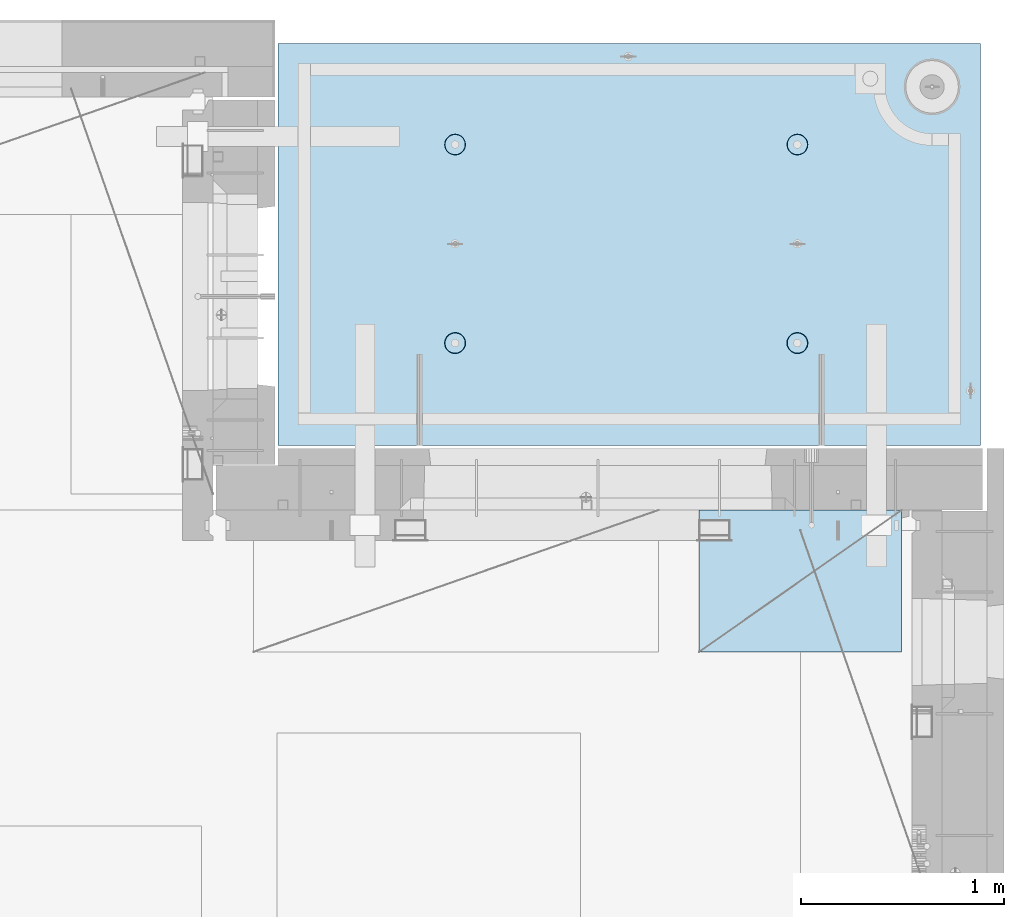
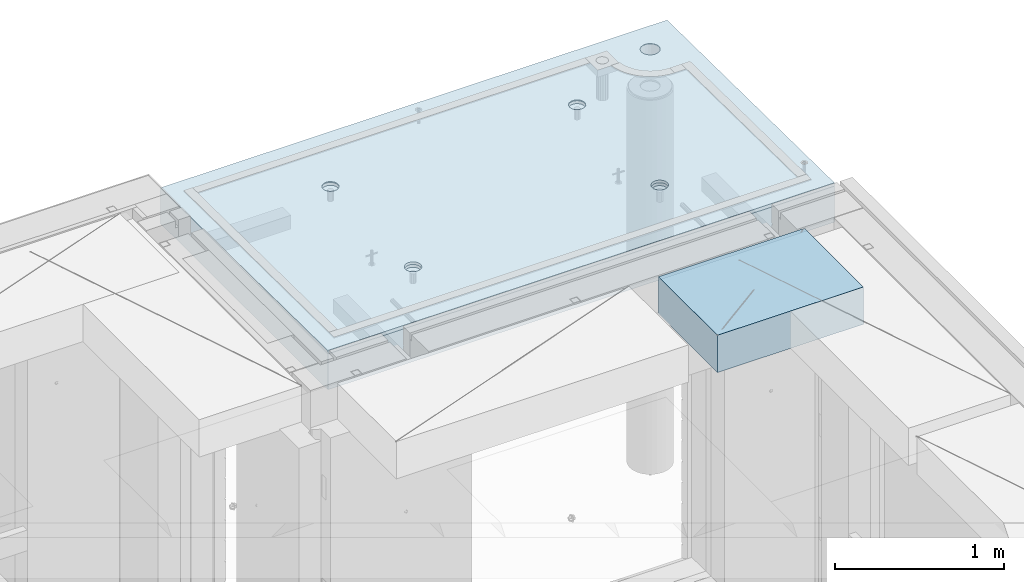
# One storey, part 211 of 349: 2 slabs, 1 plate, 2 elements without a shape of their own.
"""IFC2X3 building model written with IfcOpenShell, lengths in millimetres."""

from ifc_helpers import new_model, si_unit, frame, origin_with_axes, place, context, subcontext, project, spatial, faceted_brep, material, type_object, element, aggregate, save


model = new_model("IFC2X3")

# Units and contexts
model_context = context("Model", 3, precision=1e-05, world=origin_with_axes())
body_context = subcontext(model_context, "Body", "Model", "MODEL_VIEW")
ifc_project = project(units=[si_unit("LENGTHUNIT", "METRE", prefix="MILLI"), si_unit("AREAUNIT", "SQUARE_METRE"), si_unit("VOLUMEUNIT", "CUBIC_METRE"), si_unit("MASSUNIT", "GRAM", prefix="KILO"), si_unit("TIMEUNIT", "SECOND"), si_unit("PLANEANGLEUNIT", "RADIAN"), si_unit("SOLIDANGLEUNIT", "STERADIAN"), si_unit("THERMODYNAMICTEMPERATUREUNIT", "DEGREE_CELSIUS"), si_unit("LUMINOUSINTENSITYUNIT", "LUMEN")], contexts=[model_context])

# Site, building, storey
site_placement = place(None, origin_with_axes())
site = spatial("IfcSite", under=ifc_project, at=site_placement, CompositionType="ELEMENT")
building_placement = place(site_placement, origin_with_axes())
building = spatial("IfcBuilding", under=site, at=building_placement, CompositionType="ELEMENT")
storey_placement = place(building_placement, origin_with_axes())
storey = spatial("IfcBuildingStorey", under=building, at=storey_placement, Name="4", CompositionType="ELEMENT", Elevation=0.0)

# Assembly, slabs
assembly_1_placement = place(storey_placement, origin_with_axes())
assembly_1 = element("IfcElementAssembly", 1, at=assembly_1_placement, inside=storey, AssemblyPlace="NOTDEFINED", PredefinedType="REINFORCEMENT_UNIT")
ifc_material_1 = material(Name="CONCRETE/C35/45")
slab_type_1 = type_object("IfcSlabType", PredefinedType="NOTDEFINED")
slab_1_placement = place(assembly_1_placement, frame((31779.9998568133, 20899.9965573523, 93717.5), z_axis=(0.0, 1.0, 0.0), x_axis=(1.0, 0.0, 0.0)))
slab_1 = element("IfcSlab", 2, at=slab_1_placement, type_object=slab_type_1, material=ifc_material_1, PredefinedType="FLOOR", context=body_context, shape_type="Brep", body=[
    faceted_brep([(3287.06232936882, 9.55874156874779, 1751.46731182328), (3287.06232936882, 12.4999999999563, 1751.46731182328), (3278.5399580536, 12.4999999999563, 1734.74121634823), (3278.5399580536, 9.3480858430994, 1734.74121634823), (3265.26605352866, 12.4999999999563, 1721.46731182328), (3265.26605352866, 9.18090851265879, 1721.46731182328), (3248.5399580536, 12.4999999999563, 1712.94494050807), (3248.5399580536, 9.07357405936637, 1712.94494050807), (3229.99893839111, 12.4999999999563, 1710.00833148578), (3229.99893839111, 9.03658912732499, 1710.00833148578), (3211.45791872861, 12.4999999999563, 1712.94494050807), (3211.45791872861, 9.07357405936637, 1712.94494050807), (3194.73182325356, 12.4999999999563, 1721.46731182328), (3194.73182325356, 9.18090851267334, 1721.46731182328), (3181.45791872861, 12.4999999999563, 1734.74121634823), (3181.45791872861, 9.3480858430994, 1734.74121634823), (3172.9355474134, 12.4999999999563, 1751.46731182328), (3172.9355474134, 9.55874156874779, 1751.46731182328), (3169.99893839111, 12.4999999999563, 1770.00833148578), (3169.99893839111, 9.79225523948844, 1770.00833148578), (3172.9355474134, 12.4999999999563, 1788.54935114827), (3172.9355474134, 10.0257689102291, 1788.54935114827), (3181.45791872861, 12.4999999999563, 1805.27544662332), (3181.45791872861, 10.236424635892, 1805.27544662332), (3194.73182325356, 12.4999999999563, 1818.54935114827), (3194.73182325356, 10.4036019663181, 1818.54935114827), (3211.45791872861, 12.4999999999563, 1827.07172246349), (3211.45791872861, 10.5109364196105, 1827.07172246349), (3229.99893839111, 12.4999999999563, 1830.00833148578), (3229.99893839111, 10.5479213516664, 1830.00833148578), (3248.5399580536, 12.4999999999563, 1827.07172246349), (3248.5399580536, 10.5109364196105, 1827.07172246349), (3265.26605352866, 12.4999999999563, 1818.54935114827), (3265.26605352866, 10.4036019663181, 1818.54935114827), (3278.5399580536, 12.4999999999563, 1805.27544662332), (3278.5399580536, 10.2364246358775, 1805.27544662332), (3287.06232936882, 12.4999999999563, 1788.54935114827), (3287.06232936882, 10.0257689102291, 1788.54935114827), (3289.99893839111, 12.4999999999563, 1770.00833148578), (3289.99893839111, 9.79225523948844, 1770.00833148578), (7.41420080885291e-08, 12.4999999999927, 0.0), (-7.41420080885291e-08, -12.5, -3.63797880709171e-12), (0.0, 12.5, 1985.00366210938), (3470.0, 12.5, 0.0), (3470.00000000004, 12.4999999999563, 1985.00366210935), (3470.0, -12.5, 0.0), (2614.71871715545, -5.93617388149141, 521.168755308547), (2613.67503600632, 12.4999999999709, 520.829642746605), (2616.18047624359, 12.4999999999709, 505.010915653602), (2617.28998057371, -6.13967274603783, 505.010915653602), (2607.28293696061, -5.7526757610467, 535.738532951145), (2606.40396524136, 12.4999999999709, 535.099922616191), (2595.7125242481, -5.60710538028798, 547.296842506817), (2595.0790070157, 12.4999999999709, 546.424880841845), (2581.14006820649, -5.51366887726181, 554.715714533479), (2580.80872714612, 12.4999999999709, 553.695951606805), (2564.99000005311, -5.48147745869937, 557.271717883286), (2564.99000005311, 12.4999999999709, 556.201391844079), (2548.83993189974, -5.51366887726181, 554.715714533479), (2549.17127296011, 12.4999999999709, 553.695951606805), (2534.26747585813, -5.60710538028798, 547.296842506817), (2534.90099309052, 12.4999999999709, 546.424880841845), (2522.69706314561, -5.75267576103215, 535.738532951145), (2523.57603486487, 12.4999999999709, 535.099922616191), (2515.26128295077, -5.93617388147686, 521.168755308547), (2516.30496409991, 12.4999999999709, 520.829642746605), (2512.69001953251, -6.13967274603783, 505.010915653602), (2513.79952386263, 12.4999999999709, 505.010915653602), (2515.23823726424, -6.34326591769059, 488.84558800119), (2516.30496409991, 12.4999999999709, 489.192188560599), (2522.65977443627, -6.52701093736687, 474.256206522903), (2523.57603486487, 12.4999999999709, 474.921908691009), (2534.2301871423, -6.67288650246337, 462.673665286093), (2534.90099309052, 12.4999999999709, 463.596950465359), (2548.81688620273, -6.76656990486663, 455.235189411429), (2549.17127296011, 12.4999999999709, 456.325879700398), (2564.99000005311, -6.79885563062271, 452.67169805654), (2564.99000005311, 12.4999999999709, 453.820439463125), (2581.16311390349, -6.76656990486663, 455.235189411429), (2580.80872714612, 12.4999999999709, 456.325879700398), (2595.74981296392, -6.67288650246337, 462.673665286093), (2595.07900701571, 12.4999999999709, 463.596950465359), (2607.32022566996, -6.52701093736687, 474.256206522903), (2606.40396524136, 12.4999999999709, 474.921908691009), (2614.74176284199, -6.34326591769059, 488.84558800119), (2613.67503600632, 12.4999999999709, 489.192188560599), (924.718717121814, -5.93617388307757, 521.168755181017), (923.675035972585, 12.4999999999854, 520.829642619046), (926.180476209858, 12.4999999999854, 505.010915526043), (927.289980540074, -6.13967274762399, 505.010915526043), (917.282936926953, -5.75267576263286, 535.738532823641), (916.403965207624, 12.4999999999854, 535.099922488633), (905.712524214421, -5.60710538187413, 547.296842379335), (905.07900698197, 12.4999999999854, 546.424880714287), (891.140068172776, -5.51366887886252, 554.715714406011), (890.808727112384, 12.4999999999854, 553.695951479247), (874.990000019381, -5.48147746030008, 557.271717755822), (874.990000019381, 12.4999999999854, 556.20139171652), (858.839931865987, -5.51366887886252, 554.715714406011), (859.171272926378, 12.4999999999854, 553.695951479247), (844.267475824341, -5.60710538187413, 547.296842379335), (844.900993056792, 12.4999999999854, 546.424880714287), (832.697063111809, -5.75267576263286, 535.738532823641), (833.576034831138, 12.4999999999854, 535.099922488633), (825.261282916948, -5.93617388307757, 521.168755181017), (826.304964066177, 12.4999999999854, 520.829642619046), (822.690019498688, -6.13967274762399, 505.010915526043), (823.799523828904, 12.4999999999854, 505.010915526043), (825.238237230413, -6.34326591927675, 488.845587873602), (826.304964066174, 12.4999999999854, 489.19218843304), (832.659774402466, -6.52701093895303, 474.25620639529), (833.576034831141, 12.4999999999854, 474.921908563454), (844.230187108518, -6.67288650404953, 462.673665158458), (844.900993056788, 12.4999999999854, 463.5969503378), (858.816886168974, -6.76656990646734, 455.23518928378), (859.171272926378, 12.4999999999854, 456.32587957284), (874.990000019381, -6.79885563222342, 452.671697928887), (874.990000019381, 12.4999999999854, 453.820439335566), (891.163113869789, -6.76656990646734, 455.23518928378), (890.808727112384, 12.4999999999854, 456.32587957284), (905.749812930244, -6.67288650404953, 462.673665158458), (905.079006981974, 12.4999999999854, 463.5969503378), (917.320225636297, -6.52701093895303, 474.25620639529), (916.403965207621, 12.4999999999854, 474.921908563454), (924.741762808349, -6.34326591927675, 488.845587873602), (923.675035972588, 12.4999999999854, 489.19218843304), (924.02016693788, 6.4034111394576, 1500.93361352766), (923.67503595199, 12.4999999999854, 1500.82147367257), (926.18047618926, 12.4999999999854, 1485.00274657956), (926.555311256641, 6.20277086795249, 1485.00274657956), (916.688838773403, 6.58433162167785, 1515.29872631776), (916.403965187026, 12.4999999999854, 1515.09175354215), (905.280958178348, 6.7278571434581, 1526.69467377167), (905.079006961372, 12.4999999999854, 1526.4167117678), (890.913204613287, 6.81998112349538, 1534.0093312807), (890.808727091786, 12.4999999999854, 1533.68778253277), (874.989999998783, 6.85172034216521, 1536.52942989253), (874.989999998783, 12.4999999999854, 1536.19322277004), (859.066795384279, 6.81998112349538, 1534.0093312807), (859.17127290578, 12.4999999999854, 1533.68778253277), (844.699041819218, 6.7278571434581, 1526.69467377167), (844.900993036194, 12.4999999999854, 1526.4167117678), (833.291161224162, 6.58433162167785, 1515.29872631776), (833.57603481054, 12.4999999999854, 1515.09175354215), (825.959833059685, 6.4034111394576, 1500.93361352766), (826.304964045576, 12.4999999999854, 1500.82147367257), (823.424688740924, 6.20277086795249, 1485.00274657956), (823.799523808306, 12.4999999999854, 1485.00274657956), (825.93711110095, 6.00203761411831, 1469.06449681953), (826.304964045576, 12.4999999999854, 1469.18401948656), (833.254396317472, 5.82087370089721, 1454.68005557312), (833.57603481054, 12.4999999999854, 1454.91373961698), (844.66227690614, 5.67704728177341, 1443.26021682579), (844.90099303619, 12.4999999999854, 1443.58878139132), (859.044073415214, 5.58467987058975, 1435.9262308483), (859.17127290578, 12.4999999999854, 1436.31771062636), (874.989999998783, 5.55284766948898, 1433.39874941703), (874.989999998783, 12.4999999999854, 1433.81227038909), (890.935926582351, 5.58467987058975, 1435.9262308483), (890.808727091786, 12.4999999999854, 1436.31771062636), (905.317723091426, 5.67704728177341, 1443.26021682579), (905.079006961376, 12.4999999999854, 1443.58878139132), (916.725603680094, 5.82087370089721, 1454.68005557312), (916.403965187026, 12.4999999999854, 1454.91373961698), (924.042888896616, 6.00203761411831, 1469.06449681953), (923.67503595199, 12.4999999999854, 1469.18401948656), (2564.9899999698, 12.4999999999709, 1433.81227048016), (2564.9899999698, 5.55284767062403, 1433.39874950818), (2580.93592655335, 5.5846798717248, 1435.92623093945), (2580.8087270628, 12.4999999999709, 1436.31771071744), (2549.17127287679, 12.4999999999709, 1436.31771071744), (2549.04407338624, 5.5846798717248, 1435.92623093945), (2534.9009930072, 12.4999999999709, 1443.5887814824), (2534.66227687719, 5.67704728290846, 1443.26021691693), (2523.57603478155, 12.4999999999709, 1454.91373970805), (2523.25439628854, 5.82087370203226, 1454.68005566423), (2516.30496401659, 12.4999999999709, 1469.18401957764), (2515.93711107203, 6.00203761523881, 1469.06449691063), (2513.79952377931, 12.4999999999709, 1485.00274667064), (2513.424688712, 6.20277086908754, 1485.00274667064), (2516.30496401659, 12.4999999999709, 1500.82147376364), (2515.95983303076, 6.40341114059265, 1500.93361361872), (2523.57603478155, 12.4999999999709, 1515.09175363323), (2523.29116119523, 6.5843316228129, 1515.2987264088), (2534.90099300721, 12.4999999999709, 1526.41671185888), (2534.69904179027, 6.72785714459314, 1526.69467386269), (2549.17127287679, 12.4999999999709, 1533.68778262385), (2549.06679535531, 6.81998112463043, 1534.00933137171), (2564.9899999698, 12.4999999999709, 1536.19322286112), (2564.9899999698, 6.85172034330026, 1536.52942998354), (2580.8087270628, 12.4999999999709, 1533.68778262385), (2580.91320458428, 6.81998112463043, 1534.00933137171), (2595.07900693238, 12.4999999999709, 1526.41671185888), (2595.28095814932, 6.72785714459314, 1526.69467386269), (2606.40396515804, 12.4999999999709, 1515.09175363323), (2606.68883874436, 6.5843316228129, 1515.2987264088), (2613.675035923, 12.4999999999709, 1500.82147376364), (2614.02016690883, 6.40341114059265, 1500.93361361872), (2606.72560365105, 5.82087370203226, 1454.68005566423), (2595.3177230624, 5.67704728290846, 1443.26021691693), (2616.55531122759, 6.20277086908754, 1485.00274667064), (2614.04288886756, 6.00203761523881, 1469.06449691063), (2595.07900693239, 12.4999999999709, 1443.5887814824), (2606.40396515804, 12.4999999999709, 1454.91373970805), (2613.675035923, 12.4999999999709, 1469.18401957764), (2616.18047616028, 12.4999999999709, 1485.00274667064)], [[[0, 1, 2, 3]], [[3, 2, 4, 5]], [[5, 4, 6, 7]], [[7, 6, 8, 9]], [[9, 8, 10, 11]], [[11, 10, 12, 13]], [[13, 12, 14, 15]], [[15, 14, 16, 17]], [[17, 16, 18, 19]], [[19, 18, 20, 21]], [[21, 20, 22, 23]], [[23, 22, 24, 25]], [[25, 24, 26, 27]], [[27, 26, 28, 29]], [[29, 28, 30, 31]], [[31, 30, 32, 33]], [[33, 32, 34, 35]], [[35, 34, 36, 37]], [[37, 36, 38, 39]], [[39, 38, 1, 0]], [[40, 41, 42]], [[43, 44, 45]], [[40, 43, 45, 41]], [[46, 47, 48, 49]], [[50, 51, 47, 46]], [[52, 53, 51, 50]], [[54, 55, 53, 52]], [[56, 57, 55, 54]], [[58, 59, 57, 56]], [[59, 58, 60, 61]], [[61, 60, 62, 63]], [[63, 62, 64, 65]], [[65, 64, 66, 67]], [[67, 66, 68, 69]], [[69, 68, 70, 71]], [[71, 70, 72, 73]], [[73, 72, 74, 75]], [[75, 74, 76, 77]], [[78, 79, 77, 76]], [[80, 81, 79, 78]], [[82, 83, 81, 80]], [[84, 85, 83, 82]], [[49, 48, 85, 84]], [[86, 87, 88, 89]], [[90, 91, 87, 86]], [[92, 93, 91, 90]], [[94, 95, 93, 92]], [[96, 97, 95, 94]], [[98, 99, 97, 96]], [[99, 98, 100, 101]], [[101, 100, 102, 103]], [[103, 102, 104, 105]], [[105, 104, 106, 107]], [[107, 106, 108, 109]], [[109, 108, 110, 111]], [[111, 110, 112, 113]], [[113, 112, 114, 115]], [[115, 114, 116, 117]], [[118, 119, 117, 116]], [[120, 121, 119, 118]], [[122, 123, 121, 120]], [[124, 125, 123, 122]], [[89, 88, 125, 124]], [[126, 127, 128, 129]], [[130, 131, 127, 126]], [[132, 133, 131, 130]], [[134, 135, 133, 132]], [[136, 137, 135, 134]], [[138, 139, 137, 136]], [[140, 141, 139, 138]], [[142, 143, 141, 140]], [[143, 142, 144, 145]], [[145, 144, 146, 147]], [[147, 146, 148, 149]], [[149, 148, 150, 151]], [[151, 150, 152, 153]], [[153, 152, 154, 155]], [[155, 154, 156, 157]], [[157, 156, 158, 159]], [[159, 158, 160, 161]], [[162, 163, 161, 160]], [[164, 165, 163, 162]], [[129, 128, 165, 164]], [[166, 167, 168, 169]], [[170, 171, 167, 166]], [[172, 173, 171, 170]], [[174, 175, 173, 172]], [[176, 177, 175, 174]], [[178, 179, 177, 176]], [[180, 181, 179, 178]], [[182, 183, 181, 180]], [[183, 182, 184, 185]], [[185, 184, 186, 187]], [[187, 186, 188, 189]], [[189, 188, 190, 191]], [[191, 190, 192, 193]], [[193, 192, 194, 195]], [[195, 194, 196, 197]], [[44, 42, 41, 45], [3, 5, 7, 9, 11, 13, 15, 17, 19, 21, 23, 25, 27, 29, 31, 33, 35, 37, 39, 0], [198, 199, 168, 167, 171, 173, 175, 177, 179, 181, 183, 185, 187, 189, 191, 193, 195, 197, 200, 201], [162, 160, 158, 156, 154, 152, 150, 148, 146, 144, 142, 140, 138, 136, 134, 132, 130, 126, 129, 164], [122, 120, 118, 116, 114, 112, 110, 108, 106, 104, 102, 100, 98, 96, 94, 92, 90, 86, 89, 124], [82, 80, 78, 76, 74, 72, 70, 68, 66, 64, 62, 60, 58, 56, 54, 52, 50, 46, 49, 84]], [[169, 168, 199, 202]], [[198, 203, 202, 199]], [[201, 204, 203, 198]], [[200, 205, 204, 201]], [[197, 196, 205, 200]], [[43, 40, 42, 44], [34, 32, 30, 28, 26, 24, 22, 20, 18, 16, 14, 12, 10, 8, 6, 4, 2, 1, 38, 36], [194, 192, 190, 188, 186, 184, 182, 180, 178, 176, 174, 172, 170, 166, 169, 202, 203, 204, 205, 196], [131, 133, 135, 137, 139, 141, 143, 145, 147, 149, 151, 153, 155, 157, 159, 161, 163, 165, 128, 127], [91, 93, 95, 97, 99, 101, 103, 105, 107, 109, 111, 113, 115, 117, 119, 121, 123, 125, 88, 87], [51, 53, 55, 57, 59, 61, 63, 65, 67, 69, 71, 73, 75, 77, 79, 81, 83, 85, 48, 47]]]),
])
slab_type_2 = type_object("IfcSlabType", PredefinedType="NOTDEFINED")
slab_2_placement = place(assembly_1_placement, frame((31779.9998568132, 20899.9965573523, 93575.0), z_axis=(-1.19799915409591e-06, 0.999999999999282, 0.0), x_axis=(0.999999999999282, 1.19800000174933e-06, 0.0)))
slab_2 = element("IfcSlab", 3, at=slab_2_placement, type_object=slab_type_2, material=ifc_material_1, PredefinedType="FLOOR", context=body_context, shape_type="Brep", body=[
    faceted_brep([(2959.65048069304, -130.0, 1795.81551698422), (2959.65048069304, 130.000000000015, 1795.81551698422), (2951.52269537287, 130.000000000015, 1783.6488444481), (2951.52269537287, -130.0, 1783.6488444481), (2939.35761686434, 130.000000000015, 1775.51867349706), (2939.35761686434, -130.0, 1775.51867349706), (2925.00726809365, 130.000000000015, 1772.66274895821), (2925.00726809365, -130.0, 1772.66274895821), (2910.65635957491, 130.000000000015, 1775.51585945357), (2910.65635957491, -130.0, 1775.51585945357), (2898.48968703879, 130.000000000015, 1783.64364477374), (2898.48968703879, -130.0, 1783.64364477374), (2890.35951608775, 130.000000000015, 1795.80872328227), (2890.35951608775, -130.0, 1795.80872328227), (2887.5035915489, 130.000000000015, 1810.15907205296), (2887.5035915489, -130.0, 1810.15907205296), (2890.35670204427, 130.000000000015, 1824.5099805717), (2890.35670204427, -130.0, 1824.5099805717), (2898.48448736444, 130.000000000015, 1836.67665310783), (2898.48448736444, -130.0, 1836.67665310783), (2910.64956587296, 130.000000000015, 1844.80682405887), (2910.64956587296, -130.0, 1844.80682405887), (2924.99991464366, 130.000000000015, 1847.66274859772), (2924.99991464366, -130.0, 1847.66274859772), (2939.3508231624, 130.000000000015, 1844.80963810235), (2939.3508231624, -130.0, 1844.80963810235), (2951.51749569851, 130.000000000015, 1836.68185278219), (2951.51749569851, -130.0, 1836.68185278219), (2959.64766664955, 130.000000000015, 1824.51677427365), (2959.64766664955, -130.0, 1824.51677427365), (2962.50359118841, 130.000000000015, 1810.16642550296), (2962.50359118841, -130.0, 1810.16642550296), (3470.0, -130.0, -2.20097717829049e-09), (0.0, -130.0, -3.63797880709171e-12), (0.0, 130.0, -1.81898940354586e-12), (3470.0, 130.0, -2.20097717829049e-09), (3470.00048828125, -130.0, 1985.00366210938), (3470.00048828125, 130.0, 1985.00366210938), (0.000559809086553287, -130.0, 1985.00366210938), (0.000559809086553287, 130.0, 1985.00366210938), (890.443701616427, -110.0, 1437.44815412734), (904.382128602592, -110.0, 1444.55010256952), (915.443737652884, -110.0, 1455.61166772744), (922.54574140269, -110.0, 1469.55006653296), (924.992946242415, -110.0, 1485.00091139648), (922.545802711662, -110.0, 1500.4517659704), (915.443854269477, -110.0, 1514.39019295657), (904.382289111563, -110.0, 1525.45180200686), (890.44389030604, -110.0, 1532.55380575666), (874.993045442512, -110.0, 1535.00101059639), (859.5421908686, -110.0, 1532.55386706564), (845.603763882435, -110.0, 1525.45191862345), (834.542154832139, -110.0, 1514.39035346554), (827.440151082337, -110.0, 1500.45195466001), (824.992946242612, -110.0, 1485.00110979649), (827.440089773365, -110.0, 1469.55025522257), (834.542038215546, -110.0, 1455.61182823641), (845.603603373464, -110.0, 1444.55021918611), (859.542002178987, -110.0, 1437.44821543631), (874.992847042511, -110.0, 1435.00101059658), (923.678013579975, -130.0, 1500.81964109834), (926.183422432889, -130.0, 1485.00090903458), (916.406971127264, -130.0, 1515.08993539371), (905.082035370349, -130.0, 1526.41491608806), (890.811769926597, -130.0, 1533.68601516524), (874.993047804415, -130.0, 1536.19148678686), (859.174315740653, -130.0, 1533.68607793395), (844.904021445287, -130.0, 1526.41503548124), (833.579040750941, -130.0, 1515.09009972432), (826.307941673756, -130.0, 1500.81983428057), (823.802470052138, -130.0, 1485.00111215839), (826.307878905049, -130.0, 1469.18238009463), (833.578921357763, -130.0, 1454.91208579926), (844.903857114674, -130.0, 1443.58710510491), (859.17412255843, -130.0, 1436.31600602773), (874.992844680608, -130.0, 1433.81053440611), (890.811576744374, -130.0, 1436.31594325902), (905.081871039736, -130.0, 1443.58698571173), (916.406851734086, -130.0, 1454.91192146865), (923.677950811267, -130.0, 1469.1821869124), (890.441757333232, -110.0, 457.456323075745), (904.380184319398, -110.0, 464.558271517926), (915.44179336969, -110.0, 475.619836675844), (922.543797119495, -110.0, 489.558235481371), (924.991001959221, -110.0, 505.009080344891), (922.543858428468, -110.0, 520.459934918807), (915.441909986286, -110.0, 534.398361904972), (904.380344828369, -110.0, 545.459970955264), (890.441946022846, -110.0, 552.56197470507), (874.991101159318, -110.0, 555.009179544795), (859.540246585406, -110.0, 552.562036014042), (845.60181959924, -110.0, 545.460087571857), (834.540210548948, -110.0, 534.398522413943), (827.438206799143, -110.0, 520.46012360842), (824.991001959417, -110.0, 505.009278744892), (827.43814549017, -110.0, 489.558424170984), (834.540093932352, -110.0, 475.619997184815), (845.601659090269, -110.0, 464.558388134519), (859.540057895792, -110.0, 457.456384384717), (874.99090275932, -110.0, 455.009179544992), (923.676069296784, -130.0, 520.827810046754), (926.181478149694, -130.0, 505.009077982988), (916.405026844073, -130.0, 535.098104342116), (905.080091087159, -130.0, 546.423085036466), (890.809825643402, -130.0, 553.694184113647), (874.991103521224, -130.0, 556.199655735272), (859.172371457458, -130.0, 553.694246882354), (844.902077162096, -130.0, 546.423204429644), (833.57709646775, -130.0, 535.098268672729), (826.305997390566, -130.0, 520.828003228977), (823.800525768944, -130.0, 505.009281106795), (826.305934621854, -130.0, 489.190549043033), (833.576977074568, -130.0, 474.920254747667), (844.901912831479, -130.0, 463.595274053321), (859.172178275239, -130.0, 456.32417497614), (874.990900397414, -130.0, 453.818703354518), (890.809632461183, -130.0, 456.324112207432), (905.079926756542, -130.0, 463.595154660143), (916.404907450891, -130.0, 474.920090417054), (923.676006528072, -130.0, 489.19035586081), (2580.44175736364, -110.0, 457.452970243303), (2594.3801843498, -110.0, 464.554918685484), (2605.4417934001, -110.0, 475.616483843402), (2612.54379714991, -110.0, 489.554882648928), (2614.99100198962, -110.0, 505.005727512449), (2612.54385845887, -110.0, 520.456582086365), (2605.44191001669, -110.0, 534.39500907253), (2594.38034485878, -110.0, 545.456618122822), (2580.44194605325, -110.0, 552.558621872628), (2564.99110118972, -110.0, 555.005826712353), (2549.54024661581, -110.0, 552.5586831816), (2535.60181962965, -110.0, 545.456734739415), (2524.54021057935, -110.0, 534.395169581501), (2517.43820682954, -110.0, 520.456770775978), (2514.99100198982, -110.0, 505.00592591245), (2517.43814552058, -110.0, 489.555071338542), (2524.54009396276, -110.0, 475.616644352373), (2535.60165912067, -110.0, 464.555035302077), (2549.5400579262, -110.0, 457.453031552275), (2564.99090278973, -110.0, 455.00582671255), (2613.67606932719, -130.0, 520.824457214312), (2616.1814781801, -130.0, 505.005725150546), (2606.40502687448, -130.0, 535.094751509674), (2595.08009111756, -130.0, 546.419732204024), (2580.80982567381, -130.0, 553.690831281205), (2564.99110355163, -130.0, 556.19630290283), (2549.17237148786, -130.0, 553.690894049912), (2534.9020771925, -130.0, 546.419851597202), (2523.57709649815, -130.0, 535.094915840287), (2516.30599742097, -130.0, 520.824650396535), (2513.80052579935, -130.0, 505.005928274353), (2516.30593465226, -130.0, 489.187196210591), (2523.57697710497, -130.0, 474.916901915225), (2534.90191286189, -130.0, 463.591921220879), (2549.17217830564, -130.0, 456.320822143698), (2564.99090042782, -130.0, 453.815350522076), (2580.80963249159, -130.0, 456.32075937499), (2595.07992678695, -130.0, 463.591801827701), (2606.4049074813, -130.0, 474.916737584612), (2613.67600655848, -130.0, 489.187003028368), (2580.44370158411, -110.0, 1437.44480125841), (2594.38212857028, -110.0, 1444.5467497006), (2605.44373762057, -110.0, 1455.60831485851), (2612.54574137038, -110.0, 1469.54671366404), (2614.9929462101, -110.0, 1484.99755852756), (2612.54580267935, -110.0, 1500.44841310148), (2605.44385423717, -110.0, 1514.38684008764), (2594.38228907925, -110.0, 1525.44844913793), (2580.44389027373, -110.0, 1532.55045288774), (2564.9930454102, -110.0, 1534.99765772746), (2549.54219083629, -110.0, 1532.55051419671), (2535.60376385012, -110.0, 1525.44856575453), (2524.54215479983, -110.0, 1514.38700059661), (2517.44015105002, -110.0, 1500.44860179109), (2514.99294621029, -110.0, 1484.99775692756), (2517.44008974105, -110.0, 1469.54690235365), (2524.54203818323, -110.0, 1455.60847536748), (2535.60360334115, -110.0, 1444.54686631719), (2549.54200214667, -110.0, 1437.44486256739), (2564.9928470102, -110.0, 1434.99765772766), (2613.67801354766, -130.0, 1500.81628822942), (2616.18342240057, -130.0, 1484.99755616566), (2606.40697109495, -130.0, 1515.08658252479), (2595.08203533804, -130.0, 1526.41156321914), (2580.81176989429, -130.0, 1533.68266229632), (2564.9930477721, -130.0, 1536.18813391794), (2549.17431570834, -130.0, 1533.68272506502), (2534.90402141297, -130.0, 1526.41168261231), (2523.57904071863, -130.0, 1515.0867468554), (2516.30794164144, -130.0, 1500.81648141164), (2513.80247001983, -130.0, 1484.99775928947), (2516.30787887274, -130.0, 1469.1790272257), (2523.57892132545, -130.0, 1454.90873293034), (2534.90385708237, -130.0, 1443.58375223599), (2549.17412252611, -130.0, 1436.31265315881), (2564.99284464829, -130.0, 1433.80718153719), (2580.81157671207, -130.0, 1436.3125903901), (2595.08187100743, -130.0, 1443.58363284281), (2606.40685170178, -130.0, 1454.90856859972), (2613.67795077896, -130.0, 1469.17883404348), (3278.54339977372, -130.0, 1734.73471172154), (3265.26946891338, -130.0, 1721.46083353204), (3248.54335652997, -130.0, 1712.93849540142), (3230.00233104128, -130.0, 1710.00192316452), (3211.46131720506, -130.0, 1712.93856897219), (3194.73523863843, -130.0, 1721.46097347196), (3181.46136044892, -130.0, 1734.73490433231), (3172.9390223183, -130.0, 1751.46101671571), (3170.0024500814, -130.0, 1770.0020422044), (3172.93909588907, -130.0, 1788.54305604063), (3181.46150038884, -130.0, 1805.26913460726), (3194.73543124919, -130.0, 1818.54301279676), (3211.46154363259, -130.0, 1827.06535092738), (3230.00256912128, -130.0, 1830.00192316428), (3248.54358295751, -130.0, 1827.06527735662), (3265.26966152415, -130.0, 1818.54287285685), (3278.54353971364, -130.0, 1805.2689419965), (3287.06587784427, -130.0, 1788.5428296131), (3290.00245008117, -130.0, 1770.0018041244), (3287.0658042735, -130.0, 1751.46079028817), (3278.54353971364, 130.0, 1805.2689419965), (3287.06587784427, 130.0, 1788.5428296131), (3265.26966152415, 130.0, 1818.54287285685), (3248.54358295751, 130.0, 1827.06527735662), (3230.00256912128, 130.0, 1830.00192316428), (3211.46154363259, 130.0, 1827.06535092738), (3194.73543124919, 130.0, 1818.54301279676), (3181.46150038884, 130.0, 1805.26913460726), (3172.93909588907, 130.0, 1788.54305604063), (3170.0024500814, 130.0, 1770.0020422044), (3172.9390223183, 130.0, 1751.46101671571), (3181.46136044892, 130.0, 1734.73490433231), (3194.73523863843, 130.0, 1721.46097347196), (3211.46131720506, 130.0, 1712.93856897219), (3230.00233104128, 130.0, 1710.00192316452), (3248.54335652997, 130.0, 1712.93849540142), (3265.26946891338, 130.0, 1721.46083353204), (3278.54339977372, 130.0, 1734.73471172154), (3287.0658042735, 130.0, 1751.46079028817), (3290.00245008117, 130.0, 1770.0018041244)], [[[0, 1, 2, 3]], [[3, 2, 4, 5]], [[5, 4, 6, 7]], [[7, 6, 8, 9]], [[9, 8, 10, 11]], [[11, 10, 12, 13]], [[13, 12, 14, 15]], [[15, 14, 16, 17]], [[17, 16, 18, 19]], [[19, 18, 20, 21]], [[21, 20, 22, 23]], [[23, 22, 24, 25]], [[25, 24, 26, 27]], [[27, 26, 28, 29]], [[29, 28, 30, 31]], [[31, 30, 1, 0]], [[32, 33, 34, 35]], [[36, 32, 35, 37]], [[38, 36, 37, 39]], [[33, 38, 39, 34]], [[40, 41, 42, 43, 44, 45, 46, 47, 48, 49, 50, 51, 52, 53, 54, 55, 56, 57, 58, 59]], [[60, 45, 44, 61]], [[62, 46, 45, 60]], [[63, 47, 46, 62]], [[64, 48, 47, 63]], [[65, 49, 48, 64]], [[66, 50, 49, 65]], [[67, 51, 50, 66]], [[68, 52, 51, 67]], [[69, 53, 52, 68]], [[70, 54, 53, 69]], [[71, 55, 54, 70]], [[72, 56, 55, 71]], [[73, 57, 56, 72]], [[74, 58, 57, 73]], [[75, 59, 58, 74]], [[76, 40, 59, 75]], [[77, 41, 40, 76]], [[78, 42, 41, 77]], [[79, 43, 42, 78]], [[61, 44, 43, 79]], [[80, 81, 82, 83, 84, 85, 86, 87, 88, 89, 90, 91, 92, 93, 94, 95, 96, 97, 98, 99]], [[100, 85, 84, 101]], [[102, 86, 85, 100]], [[103, 87, 86, 102]], [[104, 88, 87, 103]], [[105, 89, 88, 104]], [[106, 90, 89, 105]], [[107, 91, 90, 106]], [[108, 92, 91, 107]], [[109, 93, 92, 108]], [[110, 94, 93, 109]], [[111, 95, 94, 110]], [[112, 96, 95, 111]], [[113, 97, 96, 112]], [[114, 98, 97, 113]], [[115, 99, 98, 114]], [[116, 80, 99, 115]], [[117, 81, 80, 116]], [[118, 82, 81, 117]], [[119, 83, 82, 118]], [[101, 84, 83, 119]], [[120, 121, 122, 123, 124, 125, 126, 127, 128, 129, 130, 131, 132, 133, 134, 135, 136, 137, 138, 139]], [[140, 125, 124, 141]], [[142, 126, 125, 140]], [[143, 127, 126, 142]], [[144, 128, 127, 143]], [[145, 129, 128, 144]], [[146, 130, 129, 145]], [[147, 131, 130, 146]], [[148, 132, 131, 147]], [[149, 133, 132, 148]], [[150, 134, 133, 149]], [[151, 135, 134, 150]], [[152, 136, 135, 151]], [[153, 137, 136, 152]], [[154, 138, 137, 153]], [[155, 139, 138, 154]], [[156, 120, 139, 155]], [[157, 121, 120, 156]], [[158, 122, 121, 157]], [[159, 123, 122, 158]], [[141, 124, 123, 159]], [[160, 161, 162, 163, 164, 165, 166, 167, 168, 169, 170, 171, 172, 173, 174, 175, 176, 177, 178, 179]], [[180, 165, 164, 181]], [[182, 166, 165, 180]], [[183, 167, 166, 182]], [[184, 168, 167, 183]], [[185, 169, 168, 184]], [[186, 170, 169, 185]], [[187, 171, 170, 186]], [[188, 172, 171, 187]], [[189, 173, 172, 188]], [[190, 174, 173, 189]], [[191, 175, 174, 190]], [[192, 176, 175, 191]], [[193, 177, 176, 192]], [[194, 178, 177, 193]], [[195, 179, 178, 194]], [[196, 160, 179, 195]], [[197, 161, 160, 196]], [[198, 162, 161, 197]], [[199, 163, 162, 198]], [[181, 164, 163, 199]], [[32, 36, 38, 33], [3, 5, 7, 9, 11, 13, 15, 17, 19, 21, 23, 25, 27, 29, 31, 0], [198, 197, 196, 195, 194, 193, 192, 191, 190, 189, 188, 187, 186, 185, 184, 183, 182, 180, 181, 199], [158, 157, 156, 155, 154, 153, 152, 151, 150, 149, 148, 147, 146, 145, 144, 143, 142, 140, 141, 159], [118, 117, 116, 115, 114, 113, 112, 111, 110, 109, 108, 107, 106, 105, 104, 103, 102, 100, 101, 119], [78, 77, 76, 75, 74, 73, 72, 71, 70, 69, 68, 67, 66, 65, 64, 63, 62, 60, 61, 79], [200, 201, 202, 203, 204, 205, 206, 207, 208, 209, 210, 211, 212, 213, 214, 215, 216, 217, 218, 219]], [[216, 220, 221, 217]], [[215, 222, 220, 216]], [[214, 223, 222, 215]], [[213, 224, 223, 214]], [[212, 225, 224, 213]], [[211, 226, 225, 212]], [[210, 227, 226, 211]], [[209, 228, 227, 210]], [[208, 229, 228, 209]], [[207, 230, 229, 208]], [[206, 231, 230, 207]], [[205, 232, 231, 206]], [[204, 233, 232, 205]], [[203, 234, 233, 204]], [[202, 235, 234, 203]], [[201, 236, 235, 202]], [[200, 237, 236, 201]], [[219, 238, 237, 200]], [[218, 239, 238, 219]], [[217, 221, 239, 218]], [[37, 35, 34, 39], [26, 24, 22, 20, 18, 16, 14, 12, 10, 8, 6, 4, 2, 1, 30, 28], [220, 222, 223, 224, 225, 226, 227, 228, 229, 230, 231, 232, 233, 234, 235, 236, 237, 238, 239, 221]]]),
])
aggregate(assembly_1, [slab_1, slab_2])

# Assembly, plate
assembly_2_placement = place(storey_placement, origin_with_axes())
assembly_2 = element("IfcElementAssembly", 4, at=assembly_2_placement, inside=storey, Name="Steel Assembly", AssemblyPlace="NOTDEFINED", PredefinedType="NOTDEFINED")
ifc_material_2 = material()
plate_type = type_object("IfcPlateType", PredefinedType="NOTDEFINED")
plate_placement = place(assembly_2_placement, frame((34860.0, 20580.0000000707, 93595.3), z_axis=(0.0, -1.0, 0.0), x_axis=(-1.0, 3.00000001838171e-08, 0.0)))
plate = element("IfcPlate", 5, at=plate_placement, type_object=plate_type, material=ifc_material_2, Name="RE1_1/2", context=body_context, shape_type="Brep", body=[
    faceted_brep([(1.81898940354586e-12, -135.0, 1.81898940354586e-12), (0.0, -135.0, 699.999999999996), (0.0, 135.0, 699.999999999996), (1.81898940354586e-12, 135.0, 1.81898940354586e-12), (999.99951171875, -135.0, 700.0), (999.99951171875, 135.0, 700.0), (1000.0, -135.0, 0.0), (1000.0, 135.0, 0.0)], [[[0, 1, 2, 3]], [[1, 4, 5, 2]], [[4, 6, 7, 5]], [[6, 0, 3, 7]], [[5, 7, 3, 2]], [[6, 4, 1, 0]]]),
])
aggregate(assembly_2, [plate])

save(model, "model.ifc")
